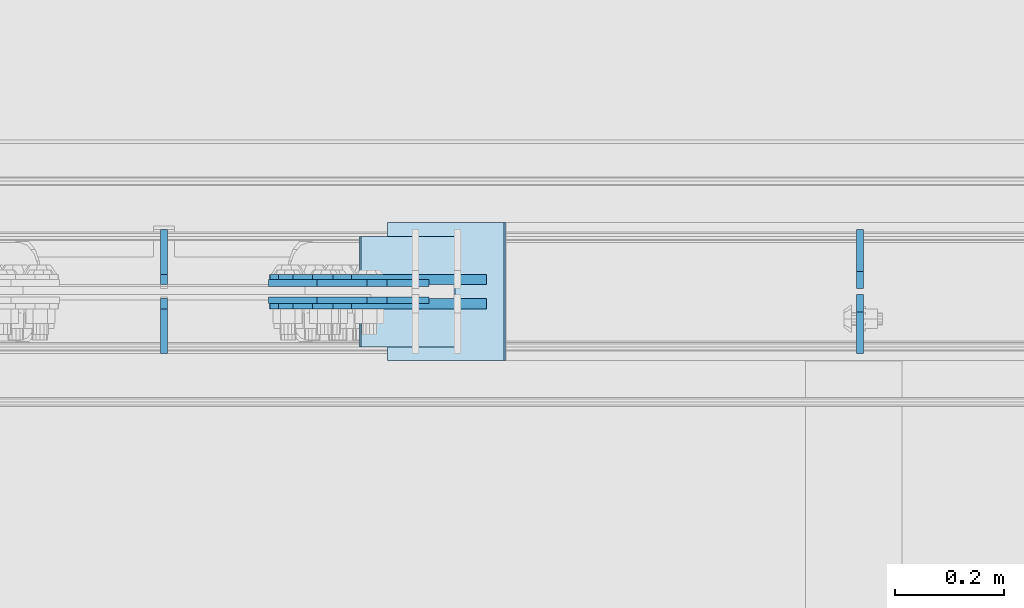
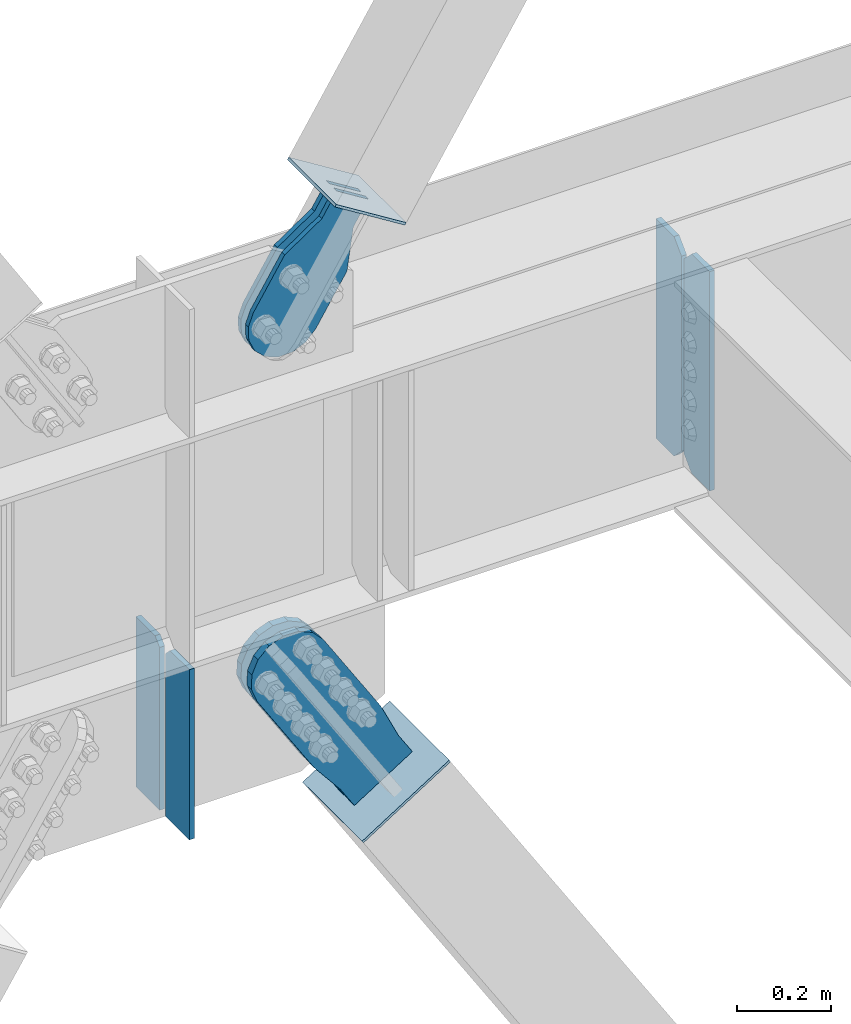
# One storey, part 3522 of 3843: 10 plates, 7 elements without a shape of their own.
"""IFC2X3 building model written with IfcOpenShell, lengths in millimetres."""

from ifc_helpers import new_model, si_unit, frame, origin_with_axes, place, context, subcontext, project, spatial, faceted_brep, material, type_object, element, aggregate, save


model = new_model("IFC2X3")

# Units and contexts
model_context = context("Model", 3, precision=1e-05, world=origin_with_axes())
body_context = subcontext(model_context, "Body", "Model", "MODEL_VIEW")
ifc_project = project(units=[si_unit("LENGTHUNIT", "METRE", prefix="MILLI"), si_unit("AREAUNIT", "SQUARE_METRE"), si_unit("VOLUMEUNIT", "CUBIC_METRE"), si_unit("MASSUNIT", "GRAM", prefix="KILO"), si_unit("TIMEUNIT", "SECOND"), si_unit("PLANEANGLEUNIT", "RADIAN"), si_unit("SOLIDANGLEUNIT", "STERADIAN"), si_unit("THERMODYNAMICTEMPERATUREUNIT", "DEGREE_CELSIUS"), si_unit("LUMINOUSINTENSITYUNIT", "LUMEN")], contexts=[model_context])

# Site, building, storey
site_placement = place(None, origin_with_axes())
site = spatial("IfcSite", under=ifc_project, at=site_placement, CompositionType="ELEMENT")
building_placement = place(site_placement, origin_with_axes())
building = spatial("IfcBuilding", under=site, at=building_placement, Name="Undefined", CompositionType="ELEMENT")
storey_placement = place(building_placement, origin_with_axes())
storey = spatial("IfcBuildingStorey", under=building, at=storey_placement, Name="Undefined", CompositionType="ELEMENT", Elevation=0.0)

# Assembly, plates
assembly_1_placement = place(storey_placement, origin_with_axes())
assembly_1 = element("IfcElementAssembly", 1, at=assembly_1_placement, inside=storey, Name="BEAM", AssemblyPlace="NOTDEFINED", PredefinedType="RIGID_FRAME")
ifc_material_1 = material(Name="STEEL/A572-50")
plate_type_1 = type_object("IfcPlateType", PredefinedType="NOTDEFINED")
plate_1_placement = place(assembly_1_placement, frame((27951.1125000954, 104564.65625, 35848.925), z_axis=(0.0, 0.0, 1.0), x_axis=(0.0, 1.0, 0.0)))
plate_1 = element("IfcPlate", 2, at=plate_1_placement, type_object=plate_type_1, material=ifc_material_1, Name="PLATE", context=body_context, shape_type="Brep", body=[
    faceted_brep([(0.0, -6.35000000000582, 31.75), (0.0, -6.34999999999854, 539.75), (0.0, 6.34999999999854, 539.75), (0.0, 6.35000000000582, 31.75), (31.75, -6.34999999999854, 571.5), (31.75, 6.34999999999854, 571.5), (108.743750000009, -6.34999999999854, 571.5), (108.743750000009, 6.34999999999854, 571.5), (108.743750000009, -6.34999999999854, 0.0), (108.743750000009, 6.34999999999854, 0.0), (31.75, -6.35000000000582, 0.0), (31.75, 6.35000000000582, 0.0)], [[[0, 1, 2, 3]], [[1, 4, 5, 2]], [[4, 6, 7, 5]], [[6, 8, 9, 7]], [[8, 10, 11, 9]], [[10, 0, 3, 11]], [[5, 7, 9, 11, 3, 2]], [[10, 8, 6, 4, 1, 0]]]),
])
plate_type_2 = type_object("IfcPlateType", PredefinedType="NOTDEFINED")
plate_2_placement = place(assembly_1_placement, frame((27951.1125000954, 104553.54375, 35848.925), z_axis=(0.0, 0.0, 1.0), x_axis=(0.0, -1.0, 0.0)))
plate_2 = element("IfcPlate", 3, at=plate_2_placement, type_object=plate_type_2, material=ifc_material_1, Name="PLATE", context=body_context, shape_type="Brep", body=[
    faceted_brep([(0.0, -6.35000000000582, 31.75), (0.0, -6.34999999999854, 539.75), (0.0, 6.34999999999854, 539.75), (0.0, 6.35000000000582, 31.75), (31.75, -6.34999999999854, 571.5), (31.75, 6.34999999999854, 571.5), (107.950000000012, -6.34999999999854, 571.5), (107.950000000012, 6.34999999999854, 571.5), (107.950000000012, -6.34999999999854, 0.0), (107.950000000012, 6.34999999999854, 0.0), (31.75, -6.35000000000582, 0.0), (31.75, 6.35000000000582, 0.0)], [[[0, 1, 2, 3]], [[1, 4, 5, 2]], [[4, 6, 7, 5]], [[6, 8, 9, 7]], [[8, 10, 11, 9]], [[10, 0, 3, 11]], [[5, 7, 9, 11, 3, 2]], [[10, 8, 6, 4, 1, 0]]]),
])

# Assembly, plate
assembly_2_placement = place(storey_placement, origin_with_axes())
assembly_2 = element("IfcElementAssembly", 4, at=assembly_2_placement, inside=storey, AssemblyPlace="NOTDEFINED", PredefinedType="RIGID_FRAME")
ifc_material_2 = material(Name="STEEL/A36")
plate_type_3 = type_object("IfcPlateType", PredefinedType="NOTDEFINED")
plate_3_placement = place(assembly_2_placement, frame((27120.8876614337, 104574.975, 36770.1963620724), z_axis=(-0.848184242744672, 0.0, 0.52970132184057), x_axis=(0.529701321840548, 0.0, 0.848184242744686)))
plate_3 = element("IfcPlate", 5, at=plate_3_placement, type_object=plate_type_3, material=ifc_material_2, context=body_context, shape_type="Brep", body=[
    faceted_brep([(0.0, -6.3499999046162, 0.0), (-101.599999999482, -6.35000000000582, -44.6881937832222), (-101.599999999482, 6.35000000000582, -44.6881937832222), (7.27595761418343e-12, 6.3499999046162, 0.0), (-246.684985846376, -6.35000000000582, -44.6881937832586), (-246.684985846376, 6.35000000000582, -44.6881937832586), (-281.313054100305, -6.35000000000582, -37.8002427490646), (-281.313054100305, 6.35000000000582, -37.8002427490646), (-310.669312866783, -6.35000000000582, -18.18501775197), (-310.669312866783, 6.35000000000582, -18.18501775197), (-330.284537863758, -6.35000000000582, 11.1712410146756), (-330.284537863758, 6.35000000000582, 11.1712410146756), (-337.172488897893, -6.35000000000582, 45.7993031645856), (-337.172488897893, 6.35000000000582, 45.7993031645856), (-330.284537863699, -6.35000000000582, 80.4273714186893), (-330.284537863699, 6.35000000000582, 80.4273714186893), (-310.669312866681, -6.35000000000582, 109.783630185331), (-310.669312866681, 6.35000000000582, 109.783630185331), (-281.313054100174, -6.35000000000582, 129.39885518244), (-281.313054100174, 6.35000000000582, 129.39885518244), (-246.684988898312, -6.35000000000582, 136.286806216667), (-246.684988898312, 6.35000000000582, 136.286806216667), (-101.599999999322, -6.35000000000582, 136.286806216689), (-101.599999999322, 6.35000000000582, 136.286806216689), (2.18278728425503e-10, -6.35000000000582, 91.5986124321353), (2.18278728425503e-10, 6.35000000000582, 91.5986124321353), (69.8499999987471, -6.35000000000582, 91.598612432037), (69.8499999987471, 6.35000000000582, 91.598612432037), (69.8499999985434, -6.35000000000582, -8.73114913702011e-11), (69.8499999985434, 6.35000000000582, -8.73114913702011e-11)], [[[0, 1, 2, 3]], [[1, 4, 5, 2]], [[4, 6, 7, 5]], [[6, 8, 9, 7]], [[8, 10, 11, 9]], [[10, 12, 13, 11]], [[12, 14, 15, 13]], [[14, 16, 17, 15]], [[16, 18, 19, 17]], [[18, 20, 21, 19]], [[20, 22, 23, 21]], [[22, 24, 25, 23]], [[24, 26, 27, 25]], [[26, 28, 29, 27]], [[28, 0, 3, 29]], [[5, 7, 9, 11, 13, 15, 17, 19, 21, 23, 25, 27, 29, 3, 2]], [[28, 26, 24, 22, 20, 18, 16, 14, 12, 10, 8, 6, 4, 1, 0]]]),
])
aggregate(assembly_2, [plate_3])

assembly_3_placement = place(storey_placement, origin_with_axes())
assembly_3 = element("IfcElementAssembly", 6, at=assembly_3_placement, inside=storey, AssemblyPlace="NOTDEFINED", PredefinedType="RIGID_FRAME")
plate_4_placement = place(assembly_3_placement, frame((27120.8876614337, 104543.225, 36770.1963620724), z_axis=(-0.848184242744672, 0.0, 0.52970132184057), x_axis=(0.529701321840548, 0.0, 0.848184242744686)))
plate_4 = element("IfcPlate", 7, at=plate_4_placement, type_object=plate_type_3, material=ifc_material_2, context=body_context, shape_type="Brep", body=[
    faceted_brep([(0.0, -6.3499999046162, 0.0), (-101.599999999482, -6.35000000000582, -44.6881937832222), (-101.599999999482, 6.35000000000582, -44.6881937832222), (7.27595761418343e-12, 6.3499999046162, 0.0), (-246.684985846376, -6.35000000000582, -44.6881937832586), (-246.684985846376, 6.35000000000582, -44.6881937832586), (-281.313054100305, -6.35000000000582, -37.8002427490646), (-281.313054100305, 6.35000000000582, -37.8002427490646), (-310.669312866783, -6.35000000000582, -18.18501775197), (-310.669312866783, 6.35000000000582, -18.18501775197), (-330.284537863758, -6.35000000000582, 11.1712410146756), (-330.284537863758, 6.35000000000582, 11.1712410146756), (-337.172488897893, -6.35000000000582, 45.7993031645856), (-337.172488897893, 6.35000000000582, 45.7993031645856), (-330.284537863699, -6.35000000000582, 80.4273714186893), (-330.284537863699, 6.35000000000582, 80.4273714186893), (-310.669312866681, -6.35000000000582, 109.783630185331), (-310.669312866681, 6.35000000000582, 109.783630185331), (-281.313054100174, -6.35000000000582, 129.39885518244), (-281.313054100174, 6.35000000000582, 129.39885518244), (-246.684988898312, -6.35000000000582, 136.286806216667), (-246.684988898312, 6.35000000000582, 136.286806216667), (-101.599999999322, -6.35000000000582, 136.286806216689), (-101.599999999322, 6.35000000000582, 136.286806216689), (2.18278728425503e-10, -6.35000000000582, 91.5986124321353), (2.18278728425503e-10, 6.35000000000582, 91.5986124321353), (69.8499999987471, -6.35000000000582, 91.598612432037), (69.8499999987471, 6.35000000000582, 91.598612432037), (69.8499999985434, -6.35000000000582, -8.73114913702011e-11), (69.8499999985434, 6.35000000000582, -8.73114913702011e-11)], [[[0, 1, 2, 3]], [[1, 4, 5, 2]], [[4, 6, 7, 5]], [[6, 8, 9, 7]], [[8, 10, 11, 9]], [[10, 12, 13, 11]], [[12, 14, 15, 13]], [[14, 16, 17, 15]], [[16, 18, 19, 17]], [[18, 20, 21, 19]], [[20, 22, 23, 21]], [[22, 24, 25, 23]], [[24, 26, 27, 25]], [[26, 28, 29, 27]], [[28, 0, 3, 29]], [[5, 7, 9, 11, 13, 15, 17, 19, 21, 23, 25, 27, 29, 3, 2]], [[28, 26, 24, 22, 20, 18, 16, 14, 12, 10, 8, 6, 4, 1, 0]]]),
])
aggregate(assembly_3, [plate_4])

assembly_4_placement = place(storey_placement, origin_with_axes())
assembly_4 = element("IfcElementAssembly", 8, at=assembly_4_placement, inside=storey, Name="Plate", AssemblyPlace="NOTDEFINED", PredefinedType="RIGID_FRAME")
plate_type_4 = type_object("IfcPlateType", PredefinedType="NOTDEFINED")
plate_5_placement = place(assembly_4_placement, frame((27203.5347663056, 104457.5, 36797.1913450867), z_axis=(-0.848184242744672, 0.0, 0.52970132184057), x_axis=(0.0, 1.0, 0.0)))
plate_5 = element("IfcPlate", 9, at=plate_5_placement, type_object=plate_type_4, material=ifc_material_2, Name="Plate", context=body_context, shape_type="Brep", body=[
    faceted_brep([(0.0, -3.17499999999927, 0.0), (0.0, -3.17500000043947, 203.200000001736), (0.0, 3.1749999995518, 203.200000001743), (0.0, 3.17499999999927, 0.0), (203.200000000012, -3.17500000043947, 203.200000001736), (203.200000000012, 3.1749999995518, 203.200000001743), (203.199996948242, -3.17499999999927, 0.0), (203.199996948242, 3.17499999999927, 0.0)], [[[0, 1, 2, 3]], [[1, 4, 5, 2]], [[4, 6, 7, 5]], [[6, 0, 3, 7]], [[5, 7, 3, 2]], [[6, 4, 1, 0]]]),
])
aggregate(assembly_4, [plate_5])

# Plate
plate_type_5 = type_object("IfcPlateType", PredefinedType="NOTDEFINED")
plate_6_placement = place(assembly_1_placement, frame((26670.0000031996, 104571.8, 35389.939062), z_axis=(0.0, 1.0, 0.0), x_axis=(0.0, 0.0, 1.0)))
plate_6 = element("IfcPlate", 10, at=plate_6_placement, type_object=plate_type_5, material=ifc_material_1, Name="CB", context=body_context, shape_type="Brep", body=[
    faceted_brep([(0.0, -6.3499999046162, 0.0), (-1.67347025126219e-10, -6.35000000000582, 101.600000000151), (-1.67347025126219e-10, 6.35000000000582, 101.600000000151), (7.27595761418343e-12, 6.3499999046162, 0.0), (443.083449679369, -6.34999999999854, 101.600000000006), (443.083449679369, 6.34999999999854, 101.600000000006), (443.083449679369, -6.34999999999854, 19.0499992370605), (443.083449679369, 6.34999999999854, 19.0499992370605), (424.033450442308, -6.34999999999854, 0.0), (424.033450442308, 6.34999999999854, 0.0)], [[[0, 1, 2, 3]], [[1, 4, 5, 2]], [[4, 6, 7, 5]], [[6, 8, 9, 7]], [[8, 0, 3, 9]], [[5, 7, 9, 3, 2]], [[8, 6, 4, 1, 0]]]),
])

plate_7_placement = place(assembly_1_placement, frame((26670.0000031996, 104546.4, 35389.939062), z_axis=(0.0, -1.0, 0.0), x_axis=(0.0, 0.0, 1.0)))
plate_7 = element("IfcPlate", 11, at=plate_7_placement, type_object=plate_type_5, material=ifc_material_1, Name="CB", context=body_context, shape_type="Brep", body=[
    faceted_brep([(0.0, -6.3499999046162, 0.0), (-1.67347025126219e-10, -6.35000000000582, 101.600000000151), (-1.67347025126219e-10, 6.35000000000582, 101.600000000151), (7.27595761418343e-12, 6.3499999046162, 0.0), (443.083449679369, -6.34999999999854, 101.600000000006), (443.083449679369, 6.34999999999854, 101.600000000006), (443.083449679369, -6.34999999999854, 19.0499992370605), (443.083449679369, 6.34999999999854, 19.0499992370605), (424.033450442308, -6.34999999999854, 0.0), (424.033450442308, 6.34999999999854, 0.0)], [[[0, 1, 2, 3]], [[1, 4, 5, 2]], [[4, 6, 7, 5]], [[6, 8, 9, 7]], [[8, 0, 3, 9]], [[5, 7, 9, 3, 2]], [[8, 6, 4, 1, 0]]]),
])

aggregate(assembly_1, [plate_1, plate_2, plate_6, plate_7])

# Assembly, plate
assembly_5_placement = place(storey_placement, origin_with_axes())
assembly_5 = element("IfcElementAssembly", 12, at=assembly_5_placement, inside=storey, AssemblyPlace="NOTDEFINED", PredefinedType="RIGID_FRAME")
plate_type_6 = type_object("IfcPlateType", PredefinedType="NOTDEFINED")
plate_8_placement = place(assembly_5_placement, frame((27226.3691435648, 104581.325, 35414.8493618866), z_axis=(-0.844597157113068, 0.0, -0.535402318071675), x_axis=(0.535402318071675, 0.0, -0.844597157113068)))
plate_8 = element("IfcPlate", 13, at=plate_8_placement, type_object=plate_type_6, material=ifc_material_2, context=body_context, shape_type="Brep", body=[
    faceted_brep([(0.0, -9.52500000000146, 0.0), (-101.599999999351, -9.52499999999418, -12.3260213857429), (-101.599999999351, 9.52499999999418, -12.3260213857429), (0.0, 9.52500000000146, 0.0), (-364.729297663791, -9.52499999999418, -12.3260213864851), (-364.729297663791, 9.52499999999418, -12.3260213864851), (-401.787405129209, -9.52499999999418, -4.95470550008758), (-401.787405129209, 9.52499999999418, -4.95470550008758), (-433.203751665707, -9.52499999999418, 16.0370261367789), (-433.203751665707, 9.52499999999418, 16.0370261367789), (-454.195483303061, -9.52499999999418, 47.4533726729569), (-454.195483303061, 9.52499999999418, 47.4533726729569), (-461.566799190045, -9.52499999999418, 84.5114770857908), (-461.566799190045, 9.52499999999418, 84.5114770857908), (-454.195483303822, -9.52499999999418, 121.569584551733), (-454.195483303822, 9.52499999999418, 121.569584551733), (-433.203751666773, -9.52499999999418, 152.985931088682), (-433.203751666773, 9.52499999999418, 152.985931088682), (-401.787405130151, -9.52499999999418, 173.977662726218), (-401.787405130151, 9.52499999999418, 173.977662726218), (-364.729299191746, -9.52499999999418, 181.348978613009), (-364.729299191746, 9.52499999999418, 181.348978613009), (-101.600000001839, -9.52499999999418, 181.348978613736), (-101.600000001839, 9.52499999999418, 181.348978613736), (-2.16823536902666e-09, -9.52499999999418, 169.022957228546), (-2.16823536902666e-09, 9.52499999999418, 169.022957228546), (69.8499999974956, -9.52499999999418, 169.02295722875), (69.8499999974956, 9.52499999999418, 169.02295722875), (69.8499999979995, -9.52499999999418, -4.00177668780088e-10), (69.8499999979995, 9.52499999999418, -4.00177668780088e-10)], [[[0, 1, 2, 3]], [[1, 4, 5, 2]], [[4, 6, 7, 5]], [[6, 8, 9, 7]], [[8, 10, 11, 9]], [[10, 12, 13, 11]], [[12, 14, 15, 13]], [[14, 16, 17, 15]], [[16, 18, 19, 17]], [[18, 20, 21, 19]], [[20, 22, 23, 21]], [[22, 24, 25, 23]], [[24, 26, 27, 25]], [[26, 28, 29, 27]], [[28, 0, 3, 29]], [[5, 7, 9, 11, 13, 15, 17, 19, 21, 23, 25, 27, 29, 3, 2]], [[28, 26, 24, 22, 20, 18, 16, 14, 12, 10, 8, 6, 4, 1, 0]]]),
])
aggregate(assembly_5, [plate_8])

assembly_6_placement = place(storey_placement, origin_with_axes())
assembly_6 = element("IfcElementAssembly", 14, at=assembly_6_placement, inside=storey, AssemblyPlace="NOTDEFINED", PredefinedType="RIGID_FRAME")
plate_9_placement = place(assembly_6_placement, frame((27226.3691435648, 104536.875, 35414.8493618866), z_axis=(-0.844597157113068, 0.0, -0.535402318071675), x_axis=(0.535402318071675, 0.0, -0.844597157113068)))
plate_9 = element("IfcPlate", 15, at=plate_9_placement, type_object=plate_type_6, material=ifc_material_2, context=body_context, shape_type="Brep", body=[
    faceted_brep([(0.0, -9.52500000000146, 0.0), (-101.599999999351, -9.52499999999418, -12.3260213857429), (-101.599999999351, 9.52499999999418, -12.3260213857429), (0.0, 9.52500000000146, 0.0), (-364.729297663791, -9.52499999999418, -12.3260213864851), (-364.729297663791, 9.52499999999418, -12.3260213864851), (-401.787405129209, -9.52499999999418, -4.95470550008758), (-401.787405129209, 9.52499999999418, -4.95470550008758), (-433.203751665707, -9.52499999999418, 16.0370261367789), (-433.203751665707, 9.52499999999418, 16.0370261367789), (-454.195483303061, -9.52499999999418, 47.4533726729569), (-454.195483303061, 9.52499999999418, 47.4533726729569), (-461.566799190045, -9.52499999999418, 84.5114770857908), (-461.566799190045, 9.52499999999418, 84.5114770857908), (-454.195483303822, -9.52499999999418, 121.569584551733), (-454.195483303822, 9.52499999999418, 121.569584551733), (-433.203751666773, -9.52499999999418, 152.985931088682), (-433.203751666773, 9.52499999999418, 152.985931088682), (-401.787405130151, -9.52499999999418, 173.977662726218), (-401.787405130151, 9.52499999999418, 173.977662726218), (-364.729299191746, -9.52499999999418, 181.348978613009), (-364.729299191746, 9.52499999999418, 181.348978613009), (-101.600000001839, -9.52499999999418, 181.348978613736), (-101.600000001839, 9.52499999999418, 181.348978613736), (-2.16823536902666e-09, -9.52499999999418, 169.022957228546), (-2.16823536902666e-09, 9.52499999999418, 169.022957228546), (69.8499999974956, -9.52499999999418, 169.02295722875), (69.8499999974956, 9.52499999999418, 169.02295722875), (69.8499999979995, -9.52499999999418, -4.00177668780088e-10), (69.8499999979995, 9.52499999999418, -4.00177668780088e-10)], [[[0, 1, 2, 3]], [[1, 4, 5, 2]], [[4, 6, 7, 5]], [[6, 8, 9, 7]], [[8, 10, 11, 9]], [[10, 12, 13, 11]], [[12, 14, 15, 13]], [[14, 16, 17, 15]], [[16, 18, 19, 17]], [[18, 20, 21, 19]], [[20, 22, 23, 21]], [[22, 24, 25, 23]], [[24, 26, 27, 25]], [[26, 28, 29, 27]], [[28, 0, 3, 29]], [[5, 7, 9, 11, 13, 15, 17, 19, 21, 23, 25, 27, 29, 3, 2]], [[28, 26, 24, 22, 20, 18, 16, 14, 12, 10, 8, 6, 4, 1, 0]]]),
])
aggregate(assembly_6, [plate_9])

assembly_7_placement = place(storey_placement, origin_with_axes())
assembly_7 = element("IfcElementAssembly", 16, at=assembly_7_placement, inside=storey, Name="Plate", AssemblyPlace="NOTDEFINED", PredefinedType="RIGID_FRAME")
plate_type_7 = type_object("IfcPlateType", PredefinedType="NOTDEFINED")
plate_10_placement = place(assembly_7_placement, frame((27083.4250997664, 104686.1, 35245.2921102539), z_axis=(0.844597157113068, 0.0, 0.535402318071675), x_axis=(0.0, -1.0, 0.0)))
plate_10 = element("IfcPlate", 17, at=plate_10_placement, type_object=plate_type_7, material=ifc_material_2, Name="Plate", context=body_context, shape_type="Brep", body=[
    faceted_brep([(0.0, -3.17499999999927, 0.0), (0.0, -3.17499999965185, 254.000000005151), (0.0, 3.17500000035216, 254.000000005166), (0.0, 3.17499999999927, 0.0), (254.0, -3.17499999965185, 254.000000005151), (254.0, 3.17500000035216, 254.000000005166), (254.0, -3.17500000000291, 0.0), (254.0, 3.17499999999927, 1.45519152283669e-11)], [[[0, 1, 2, 3]], [[1, 4, 5, 2]], [[4, 6, 7, 5]], [[6, 0, 3, 7]], [[5, 7, 3, 2]], [[6, 4, 1, 0]]]),
])
aggregate(assembly_7, [plate_10])

save(model, "model.ifc")
